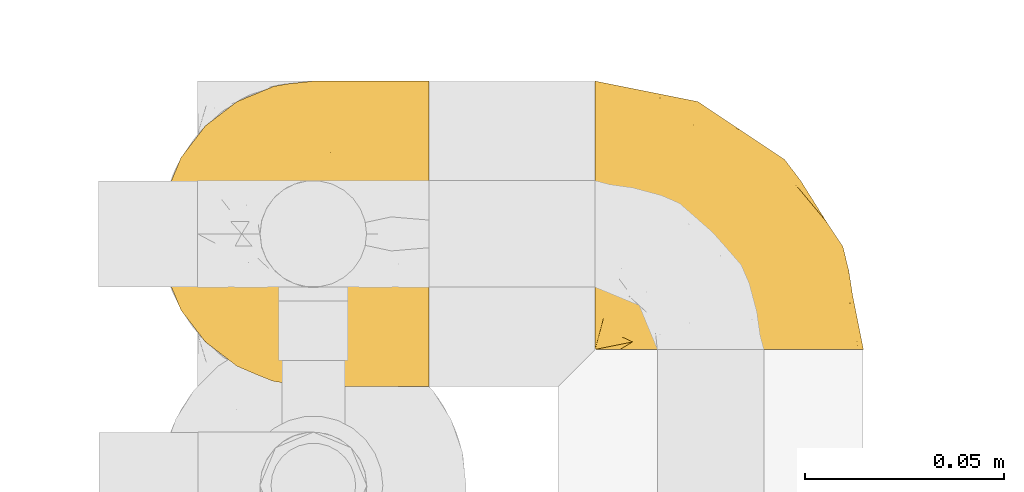
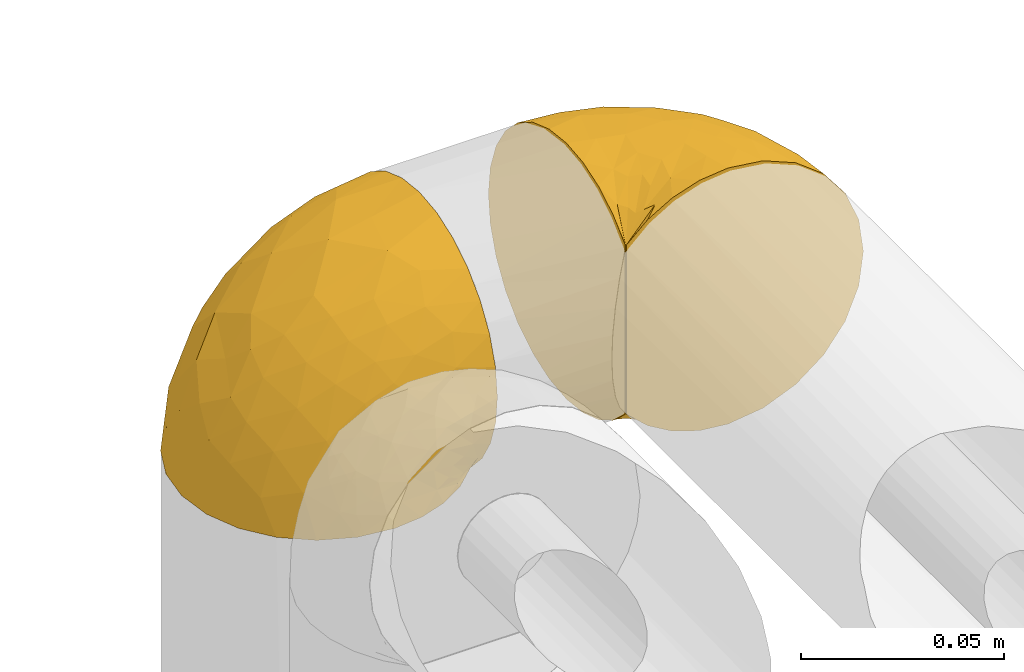
# One storey, part 85 of 827: 2 coverings.
"""IFC2X3 building model written with IfcOpenShell, lengths in millimetres."""

from ifc_helpers import new_model, entity, si_unit, converted_unit, derived_unit, direction, frame, origin, place, context, subcontext, project, spatial, faceted_brep, element, save


model = new_model("IFC2X3")

# Units and contexts
model_context = context("Model", 3, precision=0.01, world=origin(), true_north=direction((6.12303176911189e-17, 1.0)))
body_context = subcontext(model_context, "Body", "Model", "MODEL_VIEW")
ifc_project = project(units=[si_unit("LENGTHUNIT", "METRE", prefix="MILLI"), si_unit("AREAUNIT", "SQUARE_METRE"), si_unit("VOLUMEUNIT", "CUBIC_METRE"), converted_unit("PLANEANGLEUNIT", "DEGREE", entity("IfcRatioMeasure", 0.0174532925199433), si_unit("PLANEANGLEUNIT", "RADIAN"), dimensions=[0, 0, 0, 0, 0, 0, 0]), si_unit("MASSUNIT", "GRAM", prefix="KILO"), derived_unit("MASSDENSITYUNIT", [(si_unit("MASSUNIT", "GRAM", prefix="KILO"), 1), (si_unit("LENGTHUNIT", "METRE"), -3)]), derived_unit("MOMENTOFINERTIAUNIT", [(si_unit("LENGTHUNIT", "METRE"), 4)]), si_unit("TIMEUNIT", "SECOND"), si_unit("FREQUENCYUNIT", "HERTZ"), si_unit("THERMODYNAMICTEMPERATUREUNIT", "DEGREE_CELSIUS"), derived_unit("THERMALTRANSMITTANCEUNIT", [(si_unit("MASSUNIT", "GRAM", prefix="KILO"), 1), (si_unit("THERMODYNAMICTEMPERATUREUNIT", "KELVIN"), -1), (si_unit("TIMEUNIT", "SECOND"), -3)]), derived_unit("VOLUMETRICFLOWRATEUNIT", [(si_unit("LENGTHUNIT", "METRE"), 3), (si_unit("TIMEUNIT", "SECOND"), -1)]), derived_unit("MASSFLOWRATEUNIT", [(si_unit("MASSUNIT", "GRAM", prefix="KILO"), 1), (si_unit("TIMEUNIT", "SECOND"), -1)]), derived_unit("ROTATIONALFREQUENCYUNIT", [(si_unit("TIMEUNIT", "SECOND"), -1)]), si_unit("ELECTRICCURRENTUNIT", "AMPERE"), si_unit("ELECTRICVOLTAGEUNIT", "VOLT"), si_unit("POWERUNIT", "WATT"), si_unit("FORCEUNIT", "NEWTON", prefix="KILO"), si_unit("ILLUMINANCEUNIT", "LUX"), si_unit("LUMINOUSFLUXUNIT", "LUMEN"), si_unit("LUMINOUSINTENSITYUNIT", "CANDELA"), derived_unit("USERDEFINED", [(si_unit("MASSUNIT", "GRAM", prefix="KILO"), -1), (si_unit("LENGTHUNIT", "METRE"), -2), (si_unit("TIMEUNIT", "SECOND"), 3), (si_unit("LUMINOUSFLUXUNIT", "LUMEN"), 1)]), derived_unit("LINEARVELOCITYUNIT", [(si_unit("LENGTHUNIT", "METRE"), 1), (si_unit("TIMEUNIT", "SECOND"), -1)]), si_unit("PRESSUREUNIT", "PASCAL"), derived_unit("USERDEFINED", [(si_unit("LENGTHUNIT", "METRE"), -2), (si_unit("MASSUNIT", "GRAM", prefix="KILO"), 1), (si_unit("TIMEUNIT", "SECOND"), -2)]), derived_unit("LINEARFORCEUNIT", [(si_unit("MASSUNIT", "GRAM", prefix="KILO"), 1), (si_unit("LENGTHUNIT", "METRE"), 1), (si_unit("TIMEUNIT", "SECOND"), -2), (si_unit("LENGTHUNIT", "METRE"), -1)]), derived_unit("PLANARFORCEUNIT", [(si_unit("MASSUNIT", "GRAM", prefix="KILO"), 1), (si_unit("LENGTHUNIT", "METRE"), 1), (si_unit("TIMEUNIT", "SECOND"), -2), (si_unit("LENGTHUNIT", "METRE"), -2)])], contexts=[model_context])

# Site, building, storey
site_placement = place(None, origin())
site = spatial("IfcSite", under=ifc_project, at=site_placement, CompositionType="ELEMENT")
building_placement = place(site_placement, origin())
building = spatial("IfcBuilding", under=site, at=building_placement, CompositionType="ELEMENT")
storey_placement = place(building_placement, frame((0.0, 0.0, 28200.0)))
storey = spatial("IfcBuildingStorey", under=building, at=storey_placement, Name="08", CompositionType="ELEMENT", Elevation=28200.0)

# Coverings
covering_1_placement = place(storey_placement, frame((18846.09, 12179.47, 1869.3)))
element("IfcCovering", 1, at=covering_1_placement, inside=storey, Name=":ADSK_", ObjectType=":ADSK_", PredefinedType="INSULATION", context=body_context, shape_type="Brep", body=[
    faceted_brep([(69.15, 74.68, 47.38), (69.15, 70.1, 54.67), (69.15, 64.01, 60.76), (69.15, 56.72, 65.34), (69.15, 48.6, 68.18), (69.15, 40.05, 69.15), (69.15, 31.49, 68.18), (69.15, 23.36, 65.33), (69.15, 16.07, 60.75), (69.15, 9.98, 54.66), (69.15, 5.4, 47.37), (69.15, 2.56, 39.25), (69.15, 1.6, 30.7), (69.15, 2.46, 22.59), (69.15, 5.01, 14.86), (69.15, 9.13, 7.84), (69.15, 14.62, 1.85), (69.15, 16.82, 1.85), (69.15, 18.56, 1.85), (69.15, 20.52, 1.85), (69.15, 22.49, 1.85), (69.15, 24.46, 1.85), (69.15, 26.42, 1.85), (69.15, 28.39, 1.85), (69.15, 30.36, 1.85), (69.15, 32.55, 1.85), (69.15, 34.75, 1.85), (69.15, 36.94, 1.85), (69.15, 39.13, 1.85), (69.15, 41.33, 1.85), (69.15, 43.52, 1.85), (69.15, 45.72, 1.85), (69.15, 47.91, 1.85), (69.15, 50.11, 1.85), (69.15, 52.3, 1.85), (69.15, 54.49, 1.85), (69.15, 56.69, 1.85), (69.15, 58.88, 1.85), (69.15, 61.08, 1.85), (69.15, 63.27, 1.85), (69.15, 65.47, 1.85), (69.15, 70.97, 7.85), (69.15, 75.09, 14.88), (69.15, 77.64, 22.61), (69.15, 78.5, 30.7), (69.15, 77.53, 39.26), (68.89, 14.62, 1.6), (62.89, 9.12, 1.6), (55.87, 5.0, 1.6), (48.14, 2.46, 1.6), (40.05, 1.6, 1.6), (30.09, 2.91, 1.6), (20.82, 6.75, 1.6), (12.86, 12.86, 1.6), (6.75, 20.82, 1.6), (2.91, 30.09, 1.6), (1.6, 40.05, 1.6), (2.91, 50.0, 1.6), (6.75, 59.27, 1.6), (12.86, 67.23, 1.6), (20.82, 73.34, 1.6), (30.09, 77.19, 1.6), (40.05, 78.5, 1.6), (48.14, 77.63, 1.6), (55.87, 75.09, 1.6), (62.89, 70.97, 1.6), (68.89, 65.47, 1.6), (68.89, 63.27, 1.6), (68.89, 62.29, 1.6), (68.89, 60.7, 1.6), (68.89, 59.11, 1.6), (68.89, 57.52, 1.6), (68.89, 55.93, 1.6), (68.89, 54.34, 1.6), (68.89, 52.76, 1.6), (68.89, 51.17, 1.6), (68.89, 49.58, 1.6), (68.89, 47.99, 1.6), (68.89, 46.4, 1.6), (68.89, 44.81, 1.6), (68.89, 43.22, 1.6), (68.89, 41.63, 1.6), (68.89, 40.05, 1.6), (68.89, 38.46, 1.6), (68.89, 36.87, 1.6), (68.89, 35.28, 1.6), (68.89, 33.69, 1.6), (68.89, 32.1, 1.6), (68.89, 30.51, 1.6), (68.89, 28.92, 1.6), (68.89, 27.33, 1.6), (68.89, 25.37, 1.6), (68.89, 23.4, 1.6), (68.89, 21.21, 1.6), (68.89, 19.01, 1.6), (68.89, 16.82, 1.6), (68.97, 42.32, 1.78), (68.96, 44.02, 1.77), (68.97, 47.13, 1.78), (68.97, 48.74, 1.77), (68.98, 23.57, 1.79), (68.97, 25.13, 1.78), (68.96, 61.34, 1.76), (68.96, 22.02, 1.77), (68.96, 29.72, 1.77), (68.96, 56.73, 1.76), (68.96, 55.14, 1.77), (68.96, 37.66, 1.77), (69.0, 64.12, 1.8), (68.96, 28.13, 1.76), (68.96, 26.62, 1.77), (68.97, 31.46, 1.78), (68.96, 16.16, 1.77), (68.96, 39.16, 1.77), (68.96, 50.37, 1.76), (68.97, 17.69, 1.77), (68.97, 19.17, 1.78), (68.97, 62.78, 1.77), (68.96, 58.35, 1.77), (68.96, 45.53, 1.77), (68.97, 59.91, 1.78), (68.97, 65.47, 1.77), (69.02, 65.47, 1.8), (69.08, 65.47, 1.82), (68.97, 14.62, 1.77), (68.94, 14.62, 1.72), (68.92, 14.62, 1.66), (68.96, 20.59, 1.76), (68.96, 32.99, 1.77), (68.95, 34.48, 1.76), (68.96, 51.91, 1.77), (68.92, 65.47, 1.66), (68.94, 65.47, 1.72), (68.98, 53.48, 1.78), (69.08, 14.62, 1.82), (69.02, 14.62, 1.8), (68.96, 40.77, 1.77), (68.97, 35.97, 1.78), (61.33, 7.84, 3.72), (53.1, 3.53, 7.41), (63.33, 8.32, 6.13), (49.27, 1.6, 21.47), (55.53, 2.19, 19.34), (54.6, 1.6, 26.8), (41.99, 1.6, 8.87), (57.07, 4.57, 9.2), (57.95, 3.96, 12.79), (51.56, 2.28, 14.62), (41.58, 1.6, 7.34), (61.7, 7.69, 5.33), (63.33, 3.53, 17.64), (65.0, 8.32, 7.7), (67.02, 7.84, 9.41), (61.87, 1.6, 28.75), (43.94, 1.6, 16.15), (61.21, 4.34, 14.14), (63.4, 1.6, 29.16), (33.11, 29.63, 57.02), (52.82, 27.34, 64.92), (43.3, 40.05, 64.0), (33.73, 2.39, 11.92), (36.52, 2.43, 19.16), (24.87, 9.07, 28.65), (14.17, 16.64, 24.62), (18.43, 9.54, 15.19), (28.67, 4.52, 18.36), (26.0, 4.52, 9.2), (49.25, 7.49, 46.98), (59.72, 7.49, 50.24), (55.1, 12.85, 56.1), (44.72, 2.35, 28.97), (34.15, 22.66, 54.46), (5.25, 32.9, 21.34), (6.75, 25.33, 18.4), (55.54, 40.05, 66.44), (10.47, 16.64, 12.07), (25.49, 19.99, 45.49), (35.53, 16.37, 50.57), (48.22, 3.26, 36.04), (58.71, 3.75, 42.07), (57.42, 19.58, 62.12), (34.84, 7.5, 37.37), (36.87, 4.04, 29.39), (45.01, 13.94, 53.59), (44.4, 19.58, 58.06), (23.96, 28.21, 49.27), (11.2, 24.75, 29.63), (10.56, 31.42, 33.21), (16.81, 26.2, 40.1), (17.38, 33.36, 44.08), (21.38, 40.05, 49.36), (32.34, 40.05, 56.68), (4.3, 40.05, 15.2), (20.65, 16.14, 35.57), (29.66, 12.85, 41.7), (39.6, 10.47, 46.4), (42.55, 6.49, 41.41), (6.74, 40.05, 27.45), (14.06, 40.05, 38.4), (26.84, 75.57, 12.99), (5.28, 47.37, 21.33), (18.52, 52.91, 42.89), (33.13, 50.46, 57.04), (55.1, 67.23, 56.11), (57.43, 60.5, 62.13), (20.72, 70.55, 21.89), (11.46, 63.45, 16.62), (17.69, 62.61, 32.9), (49.26, 72.6, 46.99), (59.73, 72.6, 50.25), (58.71, 76.34, 42.08), (29.72, 59.34, 49.91), (35.35, 77.76, 15.6), (43.94, 78.5, 16.15), (41.99, 78.5, 8.87), (63.4, 78.5, 29.16), (4.93, 53.16, 13.16), (17.46, 70.55, 10.83), (10.94, 48.88, 33.8), (8.92, 54.76, 25.02), (52.83, 52.74, 64.92), (29.34, 71.93, 32.83), (30.26, 75.79, 20.56), (44.4, 60.5, 58.07), (39.06, 77.86, 21.46), (43.06, 77.64, 28.1), (54.6, 78.5, 26.8), (49.27, 78.5, 21.47), (42.69, 67.23, 51.29), (48.2, 76.82, 36.04), (61.87, 78.5, 28.75), (33.44, 77.8, 8.45), (29.67, 67.23, 41.73), (38.5, 73.2, 39.27), (23.35, 67.66, 33.56), (34.97, 75.99, 27.29), (53.1, 76.57, 7.41), (59.68, 73.21, 3.51), (62.19, 71.93, 4.68), (64.11, 71.07, 5.52), (57.97, 75.09, 8.75), (57.95, 76.13, 12.79), (63.33, 76.57, 17.65), (51.77, 77.69, 13.9), (67.02, 72.26, 9.42), (64.98, 71.77, 7.68), (55.53, 77.9, 19.33), (61.22, 75.75, 14.13)], [[[0, 1, 2, 3, 4, 5, 6, 7, 8, 9, 10, 11, 12, 13, 14, 15, 16, 17, 18, 19, 20, 21, 22, 23, 24, 25, 26, 27, 28, 29, 30, 31, 32, 33, 34, 35, 36, 37, 38, 39, 40, 41, 42, 43, 44, 45]], [[46, 47, 48, 49, 50, 51, 52, 53, 54, 55, 56, 57, 58, 59, 60, 61, 62, 63, 64, 65, 66, 67, 68, 69, 70, 71, 72, 73, 74, 75, 76, 77, 78, 79, 80, 81, 82, 83, 84, 85, 86, 87, 88, 89, 90, 91, 92, 93, 94, 95]], [[96, 97, 30]], [[98, 77, 99]], [[100, 101, 21]], [[69, 68, 102]], [[20, 19, 103]], [[24, 23, 104]], [[20, 103, 100]], [[72, 105, 106]], [[84, 83, 107]], [[89, 88, 104]], [[108, 67, 66]], [[109, 110, 90]], [[111, 25, 24]], [[112, 17, 16]], [[82, 113, 83]], [[109, 23, 22]], [[114, 76, 75]], [[105, 36, 106]], [[104, 111, 24]], [[18, 115, 116]], [[97, 96, 80]], [[67, 108, 117]], [[105, 71, 118]], [[31, 97, 119]], [[102, 120, 69]], [[108, 121, 122, 123, 40]], [[112, 95, 115]], [[17, 115, 18]], [[94, 116, 115]], [[117, 68, 67]], [[38, 117, 39]], [[112, 124, 125, 126, 46]], [[17, 112, 115]], [[70, 120, 118]], [[39, 117, 108]], [[120, 38, 37]], [[120, 37, 118]], [[120, 70, 69]], [[116, 94, 127]], [[128, 86, 129]], [[117, 38, 102]], [[74, 130, 75]], [[99, 33, 32]], [[115, 95, 94]], [[39, 108, 40]], [[108, 66, 131, 132, 121]], [[105, 72, 71]], [[118, 37, 36]], [[71, 70, 118]], [[35, 106, 36]], [[36, 105, 118]], [[35, 133, 106]], [[74, 73, 133]], [[106, 133, 73]], [[99, 114, 33]], [[133, 35, 34]], [[73, 72, 106]], [[95, 112, 46]], [[112, 16, 134, 135, 124]], [[130, 114, 75]], [[99, 76, 114]], [[114, 130, 33]], [[34, 33, 130]], [[78, 77, 98]], [[98, 119, 78]], [[130, 133, 34]], [[133, 130, 74]], [[79, 97, 80]], [[98, 99, 32]], [[98, 32, 31]], [[77, 76, 99]], [[97, 79, 119]], [[136, 96, 29]], [[30, 97, 31]], [[136, 29, 28]], [[81, 80, 96]], [[29, 96, 30]], [[31, 119, 98]], [[119, 79, 78]], [[96, 136, 81]], [[82, 81, 136]], [[113, 107, 83]], [[84, 107, 137]], [[107, 27, 137]], [[113, 28, 107]], [[27, 107, 28]], [[85, 84, 137]], [[137, 27, 26]], [[113, 136, 28]], [[136, 113, 82]], [[109, 89, 104]], [[86, 85, 129]], [[89, 109, 90]], [[111, 87, 128]], [[26, 129, 137]], [[88, 111, 104]], [[25, 111, 128]], [[22, 110, 109]], [[23, 109, 104]], [[110, 91, 90]], [[100, 92, 101]], [[110, 22, 101]], [[91, 110, 101]], [[116, 19, 18]], [[111, 88, 87]], [[127, 103, 19]], [[25, 128, 26]], [[86, 128, 87]], [[128, 129, 26]], [[137, 129, 85]], [[120, 102, 38]], [[117, 102, 68]], [[91, 101, 92]], [[21, 101, 22]], [[93, 92, 103]], [[100, 21, 20]], [[100, 103, 92]], [[127, 93, 103]], [[93, 127, 94]], [[116, 127, 19]], [[126, 138, 47]], [[48, 138, 139]], [[140, 125, 124]], [[141, 142, 143]], [[144, 49, 139]], [[145, 140, 146]], [[48, 139, 49]], [[139, 145, 147]], [[49, 144, 148, 50]], [[126, 125, 149]], [[14, 13, 150]], [[151, 146, 140]], [[149, 140, 145]], [[152, 151, 135]], [[152, 14, 150]], [[16, 15, 134]], [[13, 153, 150]], [[124, 151, 140]], [[141, 147, 142]], [[14, 152, 15]], [[15, 152, 134]], [[47, 46, 126]], [[139, 154, 144]], [[138, 48, 47]], [[125, 140, 149]], [[135, 134, 152]], [[146, 155, 142]], [[145, 146, 147]], [[149, 139, 138]], [[147, 141, 154]], [[147, 146, 142]], [[139, 147, 154]], [[139, 149, 145]], [[149, 138, 126]], [[155, 146, 151]], [[150, 143, 142]], [[152, 155, 151]], [[150, 142, 155]], [[13, 12, 156, 153]], [[153, 143, 150]], [[152, 150, 155]], [[151, 124, 135]], [[157, 158, 159]], [[160, 154, 161]], [[162, 163, 164]], [[165, 166, 160]], [[167, 168, 169]], [[141, 170, 161]], [[156, 12, 11]], [[158, 157, 171]], [[172, 55, 173]], [[158, 6, 174]], [[175, 54, 53]], [[52, 166, 164]], [[52, 164, 53]], [[54, 175, 173]], [[166, 52, 51]], [[176, 177, 171]], [[178, 143, 179]], [[156, 11, 179]], [[8, 7, 180]], [[169, 9, 8]], [[179, 143, 153, 156]], [[179, 11, 10]], [[168, 179, 10]], [[181, 162, 182]], [[179, 167, 178]], [[183, 184, 177]], [[183, 169, 184]], [[176, 171, 185]], [[172, 186, 187]], [[158, 7, 6]], [[159, 158, 174]], [[184, 180, 158]], [[54, 173, 55]], [[180, 169, 8]], [[188, 189, 187]], [[9, 168, 10]], [[186, 188, 187]], [[190, 157, 159, 191]], [[55, 172, 192]], [[176, 193, 194]], [[161, 170, 182]], [[162, 164, 165]], [[175, 164, 163]], [[51, 50, 148]], [[167, 195, 196]], [[178, 182, 170]], [[6, 5, 174]], [[158, 180, 7]], [[169, 180, 184]], [[169, 168, 9]], [[179, 168, 167]], [[182, 162, 165]], [[162, 194, 193]], [[161, 165, 160]], [[195, 181, 196]], [[192, 172, 197]], [[192, 56, 55]], [[189, 190, 198]], [[198, 197, 187]], [[172, 187, 197]], [[185, 189, 188]], [[198, 187, 189]], [[186, 172, 173]], [[173, 163, 186]], [[193, 186, 163]], [[176, 185, 188]], [[185, 157, 190]], [[188, 186, 193]], [[177, 176, 194]], [[188, 193, 176]], [[162, 193, 163]], [[195, 177, 194]], [[171, 177, 184]], [[181, 195, 194]], [[183, 167, 169]], [[162, 181, 194]], [[196, 182, 178]], [[158, 171, 184]], [[171, 157, 185]], [[177, 195, 183]], [[167, 183, 195]], [[182, 196, 181]], [[178, 170, 143]], [[178, 167, 196]], [[164, 175, 53]], [[173, 175, 163]], [[160, 51, 148]], [[164, 166, 165]], [[51, 160, 166]], [[160, 148, 144, 154]], [[141, 161, 154]], [[182, 165, 161]], [[190, 189, 185]], [[143, 170, 141]], [[60, 199, 61]], [[197, 200, 192]], [[201, 190, 202]], [[200, 57, 192]], [[203, 204, 2]], [[205, 206, 207]], [[208, 209, 210]], [[211, 207, 201]], [[212, 213, 214]], [[45, 215, 210]], [[216, 206, 58]], [[45, 44, 215]], [[59, 217, 60]], [[60, 217, 199]], [[0, 45, 210]], [[218, 201, 219]], [[202, 159, 220]], [[205, 221, 222]], [[223, 204, 203]], [[1, 203, 2]], [[57, 200, 216]], [[220, 3, 204]], [[220, 174, 4]], [[1, 0, 209]], [[212, 224, 213]], [[225, 226, 227]], [[228, 223, 203]], [[208, 210, 229]], [[210, 226, 229]], [[3, 220, 4]], [[58, 206, 59]], [[209, 203, 1]], [[202, 220, 223]], [[228, 203, 208]], [[202, 211, 201]], [[3, 2, 204]], [[202, 190, 191, 159]], [[210, 215, 230, 226]], [[199, 212, 231]], [[232, 233, 221]], [[233, 208, 229]], [[207, 206, 219]], [[217, 206, 205]], [[227, 224, 225]], [[233, 232, 228]], [[201, 207, 219]], [[234, 232, 221]], [[218, 219, 200]], [[202, 223, 211]], [[174, 220, 159]], [[174, 5, 4]], [[61, 231, 62]], [[220, 204, 223]], [[210, 209, 0]], [[203, 209, 208]], [[225, 233, 229]], [[224, 227, 213]], [[221, 233, 235]], [[57, 56, 192]], [[198, 218, 197]], [[200, 219, 216]], [[201, 198, 190]], [[197, 218, 200]], [[198, 201, 218]], [[206, 216, 219]], [[58, 57, 216]], [[231, 212, 214]], [[222, 212, 199]], [[228, 211, 223]], [[207, 211, 232]], [[62, 231, 214]], [[199, 231, 61]], [[233, 228, 208]], [[211, 228, 232]], [[222, 221, 235]], [[234, 205, 207]], [[206, 217, 59]], [[199, 217, 205]], [[205, 222, 199]], [[224, 222, 235]], [[222, 224, 212]], [[224, 235, 225]], [[233, 225, 235]], [[226, 225, 229]], [[205, 234, 221]], [[207, 232, 234]], [[63, 214, 236]], [[214, 213, 236]], [[214, 63, 62]], [[237, 236, 238]], [[238, 132, 131]], [[236, 237, 64]], [[239, 240, 241]], [[63, 236, 64]], [[131, 66, 65]], [[237, 131, 65]], [[242, 230, 43]], [[237, 65, 64]], [[239, 121, 132]], [[42, 242, 43]], [[241, 240, 243]], [[41, 123, 244]], [[43, 230, 215, 44]], [[244, 122, 245]], [[227, 246, 243]], [[241, 243, 246]], [[121, 239, 245]], [[41, 40, 123]], [[132, 238, 239]], [[244, 42, 41]], [[131, 237, 238]], [[240, 239, 238]], [[245, 239, 241]], [[247, 241, 246]], [[247, 244, 245]], [[238, 236, 240]], [[243, 236, 213]], [[236, 243, 240]], [[226, 246, 227]], [[243, 213, 227]], [[226, 242, 246]], [[241, 247, 245]], [[246, 242, 247]], [[244, 247, 242]], [[242, 226, 230]], [[42, 244, 242]], [[122, 244, 123]], [[122, 121, 245]]]),
])
covering_2_placement = place(storey_placement, frame((18955.44, 12188.82, 1859.95)))
element("IfcCovering", 2, at=covering_2_placement, inside=storey, Name=":ADSK_", ObjectType=":ADSK_", PredefinedType="INSULATION", context=body_context, shape_type="Brep", body=[
    faceted_brep([(1.6, 47.38, 74.68), (1.6, 54.67, 70.1), (1.6, 60.76, 64.01), (1.6, 65.34, 56.72), (1.6, 68.18, 48.6), (1.6, 69.15, 40.05), (1.6, 68.18, 31.49), (1.6, 65.33, 23.36), (1.6, 60.75, 16.07), (1.6, 54.66, 9.98), (1.6, 47.37, 5.4), (1.6, 39.25, 2.56), (1.6, 30.7, 1.6), (1.6, 22.59, 2.46), (1.6, 14.86, 5.01), (1.6, 7.84, 9.13), (1.6, 1.85, 14.62), (1.6, 1.85, 16.82), (1.6, 1.85, 18.56), (1.6, 1.85, 20.52), (1.6, 1.85, 22.49), (1.6, 1.85, 24.46), (1.6, 1.85, 26.42), (1.6, 1.85, 28.39), (1.6, 1.85, 30.36), (1.6, 1.85, 32.55), (1.6, 1.85, 34.75), (1.6, 1.85, 36.94), (1.6, 1.85, 39.13), (1.6, 1.85, 41.33), (1.6, 1.85, 43.52), (1.6, 1.85, 45.72), (1.6, 1.85, 47.91), (1.6, 1.85, 50.11), (1.6, 1.85, 52.3), (1.6, 1.85, 54.49), (1.6, 1.85, 56.69), (1.6, 1.85, 58.88), (1.6, 1.85, 61.08), (1.6, 1.85, 63.27), (1.6, 1.85, 65.47), (1.6, 7.85, 70.97), (1.6, 14.88, 75.09), (1.6, 22.61, 77.64), (1.6, 30.7, 78.5), (1.6, 39.26, 77.53), (1.85, 1.6, 14.62), (7.85, 1.6, 9.12), (14.87, 1.6, 5.0), (22.6, 1.6, 2.46), (30.7, 1.6, 1.6), (40.65, 1.6, 2.91), (49.92, 1.6, 6.75), (57.88, 1.6, 12.86), (63.99, 1.6, 20.82), (67.84, 1.6, 30.09), (69.15, 1.6, 40.05), (67.84, 1.6, 50.0), (63.99, 1.6, 59.27), (57.88, 1.6, 67.23), (49.92, 1.6, 73.34), (40.65, 1.6, 77.19), (30.7, 1.6, 78.5), (22.6, 1.6, 77.63), (14.87, 1.6, 75.09), (7.85, 1.6, 70.97), (1.85, 1.6, 65.47), (1.85, 1.6, 63.27), (1.85, 1.6, 62.29), (1.85, 1.6, 60.7), (1.85, 1.6, 59.11), (1.85, 1.6, 57.52), (1.85, 1.6, 55.93), (1.85, 1.6, 54.34), (1.85, 1.6, 52.76), (1.85, 1.6, 51.17), (1.85, 1.6, 49.58), (1.85, 1.6, 47.99), (1.85, 1.6, 46.4), (1.85, 1.6, 44.81), (1.85, 1.6, 43.22), (1.85, 1.6, 41.63), (1.85, 1.6, 40.05), (1.85, 1.6, 38.46), (1.85, 1.6, 36.87), (1.85, 1.6, 35.28), (1.85, 1.6, 33.69), (1.85, 1.6, 32.1), (1.85, 1.6, 30.51), (1.85, 1.6, 28.92), (1.85, 1.6, 27.33), (1.85, 1.6, 25.37), (1.85, 1.6, 23.4), (1.85, 1.6, 21.21), (1.85, 1.6, 19.01), (1.85, 1.6, 16.82), (1.77, 1.78, 42.32), (1.78, 1.77, 44.02), (1.77, 1.78, 47.13), (1.77, 1.77, 48.74), (1.76, 1.79, 23.57), (1.77, 1.78, 25.13), (1.79, 1.76, 61.34), (1.78, 1.77, 22.02), (1.78, 1.77, 29.72), (1.78, 1.76, 56.73), (1.78, 1.77, 55.14), (1.78, 1.77, 37.66), (1.74, 1.8, 64.12), (1.78, 1.76, 28.13), (1.78, 1.77, 26.62), (1.77, 1.78, 31.46), (1.78, 1.77, 16.16), (1.78, 1.77, 39.16), (1.78, 1.76, 50.37), (1.77, 1.77, 17.69), (1.77, 1.78, 19.17), (1.77, 1.77, 62.78), (1.78, 1.77, 58.35), (1.78, 1.77, 45.53), (1.77, 1.78, 59.91), (1.77, 1.77, 65.47), (1.72, 1.8, 65.47), (1.66, 1.82, 65.47), (1.77, 1.77, 14.62), (1.8, 1.72, 14.62), (1.82, 1.66, 14.62), (1.79, 1.76, 20.59), (1.78, 1.77, 32.99), (1.79, 1.76, 34.48), (1.78, 1.77, 51.91), (1.82, 1.66, 65.47), (1.8, 1.72, 65.47), (1.76, 1.78, 53.48), (1.66, 1.82, 14.62), (1.72, 1.8, 14.62), (1.78, 1.77, 40.77), (1.77, 1.78, 35.97), (9.41, 3.72, 7.84), (17.65, 7.41, 3.53), (7.41, 6.13, 8.32), (15.21, 19.34, 2.19), (7.41, 17.64, 3.53), (16.15, 26.8, 1.6), (28.75, 8.87, 1.6), (13.67, 9.2, 4.57), (12.79, 12.79, 3.96), (19.18, 14.62, 2.28), (29.16, 7.34, 1.6), (9.04, 5.33, 7.69), (5.74, 7.7, 8.32), (3.72, 9.41, 7.84), (8.87, 28.75, 1.6), (21.47, 21.47, 1.6), (26.8, 16.15, 1.6), (9.53, 14.14, 4.34), (7.34, 29.16, 1.6), (37.63, 57.02, 29.63), (17.92, 64.92, 27.34), (27.45, 64.0, 40.05), (37.01, 11.92, 2.39), (34.22, 19.16, 2.43), (45.87, 28.65, 9.07), (56.57, 24.62, 16.64), (52.31, 15.19, 9.54), (42.07, 18.36, 4.52), (44.74, 9.2, 4.52), (21.49, 46.98, 7.49), (11.02, 50.24, 7.49), (15.64, 56.1, 12.85), (26.02, 28.97, 2.35), (36.59, 54.46, 22.66), (65.49, 21.34, 32.9), (63.99, 18.4, 25.33), (15.2, 66.44, 40.05), (60.27, 12.07, 16.64), (45.25, 45.49, 19.99), (35.21, 50.57, 16.37), (22.52, 36.04, 3.26), (12.03, 42.07, 3.75), (13.32, 62.12, 19.58), (35.9, 37.37, 7.5), (33.87, 29.39, 4.04), (25.73, 53.59, 13.94), (26.34, 58.06, 19.58), (46.78, 49.27, 28.21), (59.54, 29.63, 24.75), (60.18, 33.21, 31.42), (53.93, 40.1, 26.2), (53.36, 44.08, 33.36), (49.36, 49.36, 40.05), (38.4, 56.68, 40.05), (66.44, 15.2, 40.05), (50.09, 35.57, 16.14), (41.08, 41.7, 12.85), (31.14, 46.4, 10.47), (28.19, 41.41, 6.49), (64.0, 27.45, 40.05), (56.68, 38.4, 40.05), (43.9, 12.99, 75.57), (65.46, 21.33, 47.37), (52.22, 42.89, 52.91), (37.61, 57.04, 50.46), (15.64, 56.11, 67.23), (13.31, 62.13, 60.5), (50.02, 21.89, 70.55), (59.28, 16.62, 63.45), (53.05, 32.9, 62.61), (21.48, 46.99, 72.6), (11.01, 50.25, 72.6), (12.03, 42.08, 76.34), (41.02, 49.91, 59.34), (35.39, 15.6, 77.76), (26.8, 16.15, 78.5), (28.75, 8.87, 78.5), (7.34, 29.16, 78.5), (65.81, 13.16, 53.16), (53.28, 10.83, 70.55), (59.8, 33.8, 48.88), (61.82, 25.02, 54.76), (17.91, 64.92, 52.74), (41.4, 32.83, 71.93), (40.48, 20.56, 75.79), (26.34, 58.07, 60.5), (31.68, 21.46, 77.86), (27.68, 28.1, 77.64), (16.15, 26.8, 78.5), (21.47, 21.47, 78.5), (28.05, 51.29, 67.23), (22.54, 36.04, 76.82), (8.87, 28.75, 78.5), (37.3, 8.45, 77.8), (41.07, 41.73, 67.23), (32.24, 39.27, 73.2), (47.4, 33.56, 67.66), (35.77, 27.29, 75.99), (17.65, 7.41, 76.57), (11.06, 3.51, 73.21), (8.55, 4.68, 71.93), (6.63, 5.52, 71.07), (12.77, 8.75, 75.09), (12.79, 12.79, 76.13), (7.41, 17.65, 76.57), (18.97, 13.9, 77.69), (3.72, 9.42, 72.26), (5.76, 7.68, 71.77), (15.21, 19.33, 77.9), (9.52, 14.13, 75.75)], [[[0, 1, 2, 3, 4, 5, 6, 7, 8, 9, 10, 11, 12, 13, 14, 15, 16, 17, 18, 19, 20, 21, 22, 23, 24, 25, 26, 27, 28, 29, 30, 31, 32, 33, 34, 35, 36, 37, 38, 39, 40, 41, 42, 43, 44, 45]], [[46, 47, 48, 49, 50, 51, 52, 53, 54, 55, 56, 57, 58, 59, 60, 61, 62, 63, 64, 65, 66, 67, 68, 69, 70, 71, 72, 73, 74, 75, 76, 77, 78, 79, 80, 81, 82, 83, 84, 85, 86, 87, 88, 89, 90, 91, 92, 93, 94, 95]], [[96, 97, 30]], [[98, 77, 99]], [[100, 101, 21]], [[69, 68, 102]], [[20, 19, 103]], [[24, 23, 104]], [[20, 103, 100]], [[72, 105, 106]], [[84, 83, 107]], [[89, 88, 104]], [[108, 67, 66]], [[109, 110, 90]], [[111, 25, 24]], [[112, 17, 16]], [[82, 113, 83]], [[109, 23, 22]], [[114, 76, 75]], [[105, 36, 106]], [[104, 111, 24]], [[18, 115, 116]], [[97, 96, 80]], [[67, 108, 117]], [[105, 71, 118]], [[31, 97, 119]], [[102, 120, 69]], [[108, 121, 122, 123, 40]], [[112, 95, 115]], [[17, 115, 18]], [[94, 116, 115]], [[117, 68, 67]], [[38, 117, 39]], [[112, 124, 125, 126, 46]], [[17, 112, 115]], [[70, 120, 118]], [[39, 117, 108]], [[120, 38, 37]], [[120, 37, 118]], [[120, 70, 69]], [[116, 94, 127]], [[128, 86, 129]], [[117, 38, 102]], [[74, 130, 75]], [[99, 33, 32]], [[115, 95, 94]], [[39, 108, 40]], [[108, 66, 131, 132, 121]], [[105, 72, 71]], [[118, 37, 36]], [[71, 70, 118]], [[35, 106, 36]], [[36, 105, 118]], [[35, 133, 106]], [[74, 73, 133]], [[106, 133, 73]], [[99, 114, 33]], [[133, 35, 34]], [[73, 72, 106]], [[95, 112, 46]], [[112, 16, 134, 135, 124]], [[130, 114, 75]], [[99, 76, 114]], [[114, 130, 33]], [[34, 33, 130]], [[78, 77, 98]], [[98, 119, 78]], [[130, 133, 34]], [[133, 130, 74]], [[79, 97, 80]], [[98, 99, 32]], [[98, 32, 31]], [[77, 76, 99]], [[97, 79, 119]], [[136, 96, 29]], [[30, 97, 31]], [[136, 29, 28]], [[81, 80, 96]], [[29, 96, 30]], [[31, 119, 98]], [[119, 79, 78]], [[96, 136, 81]], [[82, 81, 136]], [[113, 107, 83]], [[84, 107, 137]], [[107, 27, 137]], [[113, 28, 107]], [[27, 107, 28]], [[85, 84, 137]], [[137, 27, 26]], [[113, 136, 28]], [[136, 113, 82]], [[109, 89, 104]], [[86, 85, 129]], [[89, 109, 90]], [[111, 87, 128]], [[26, 129, 137]], [[88, 111, 104]], [[25, 111, 128]], [[22, 110, 109]], [[23, 109, 104]], [[110, 91, 90]], [[100, 92, 101]], [[110, 22, 101]], [[91, 110, 101]], [[116, 19, 18]], [[111, 88, 87]], [[127, 103, 19]], [[25, 128, 26]], [[86, 128, 87]], [[128, 129, 26]], [[137, 129, 85]], [[120, 102, 38]], [[117, 102, 68]], [[91, 101, 92]], [[21, 101, 22]], [[93, 92, 103]], [[100, 21, 20]], [[100, 103, 92]], [[127, 93, 103]], [[93, 127, 94]], [[116, 127, 19]], [[126, 138, 47]], [[48, 138, 139]], [[140, 125, 124]], [[141, 142, 143]], [[144, 49, 139]], [[145, 140, 146]], [[48, 139, 49]], [[139, 145, 147]], [[49, 144, 148, 50]], [[126, 125, 149]], [[14, 13, 142]], [[150, 146, 140]], [[149, 140, 145]], [[151, 150, 135]], [[151, 14, 142]], [[16, 15, 134]], [[13, 152, 142]], [[124, 150, 140]], [[141, 143, 153]], [[14, 151, 15]], [[15, 151, 134]], [[47, 46, 126]], [[139, 154, 144]], [[138, 48, 47]], [[125, 140, 149]], [[135, 134, 151]], [[146, 155, 141]], [[145, 146, 147]], [[149, 139, 138]], [[147, 153, 154]], [[147, 146, 141]], [[139, 147, 154]], [[139, 149, 145]], [[149, 138, 126]], [[147, 141, 153]], [[146, 150, 155]], [[151, 155, 150]], [[142, 141, 155]], [[13, 12, 156, 152]], [[152, 143, 142]], [[151, 142, 155]], [[150, 124, 135]], [[157, 158, 159]], [[160, 154, 161]], [[162, 163, 164]], [[165, 166, 160]], [[167, 168, 169]], [[153, 170, 161]], [[156, 12, 11]], [[158, 157, 171]], [[172, 55, 173]], [[158, 6, 174]], [[175, 54, 53]], [[52, 166, 164]], [[52, 164, 53]], [[54, 175, 173]], [[166, 52, 51]], [[176, 177, 171]], [[178, 143, 179]], [[156, 11, 179]], [[8, 7, 180]], [[169, 9, 8]], [[179, 143, 152, 156]], [[179, 11, 10]], [[168, 179, 10]], [[181, 162, 182]], [[179, 167, 178]], [[183, 184, 177]], [[183, 169, 184]], [[176, 171, 185]], [[172, 186, 187]], [[158, 7, 6]], [[159, 158, 174]], [[184, 180, 158]], [[54, 173, 55]], [[180, 169, 8]], [[188, 189, 187]], [[9, 168, 10]], [[186, 188, 187]], [[190, 157, 159, 191]], [[55, 172, 192]], [[176, 193, 194]], [[161, 170, 182]], [[162, 164, 165]], [[175, 164, 163]], [[51, 50, 148]], [[167, 195, 196]], [[178, 182, 170]], [[6, 5, 174]], [[158, 180, 7]], [[169, 180, 184]], [[169, 168, 9]], [[179, 168, 167]], [[182, 162, 165]], [[162, 194, 193]], [[161, 165, 160]], [[195, 181, 196]], [[192, 172, 197]], [[192, 56, 55]], [[189, 190, 198]], [[198, 197, 187]], [[172, 187, 197]], [[185, 189, 188]], [[198, 187, 189]], [[186, 172, 173]], [[173, 163, 186]], [[193, 186, 163]], [[176, 185, 188]], [[185, 157, 190]], [[188, 186, 193]], [[177, 176, 194]], [[188, 193, 176]], [[162, 193, 163]], [[195, 177, 194]], [[171, 177, 184]], [[181, 195, 194]], [[183, 167, 169]], [[162, 181, 194]], [[196, 182, 178]], [[158, 171, 184]], [[171, 157, 185]], [[177, 195, 183]], [[167, 183, 195]], [[182, 196, 181]], [[178, 170, 143]], [[178, 167, 196]], [[164, 175, 53]], [[173, 175, 163]], [[160, 51, 148]], [[164, 166, 165]], [[51, 160, 166]], [[160, 148, 144, 154]], [[153, 161, 154]], [[182, 165, 161]], [[190, 189, 185]], [[143, 170, 153]], [[60, 199, 61]], [[197, 200, 192]], [[201, 190, 202]], [[200, 57, 192]], [[203, 204, 2]], [[205, 206, 207]], [[208, 209, 210]], [[211, 207, 201]], [[212, 213, 214]], [[45, 215, 210]], [[216, 206, 58]], [[45, 44, 215]], [[59, 217, 60]], [[60, 217, 199]], [[0, 45, 210]], [[218, 201, 219]], [[202, 159, 220]], [[205, 221, 222]], [[223, 204, 203]], [[1, 203, 2]], [[57, 200, 216]], [[220, 3, 204]], [[220, 174, 4]], [[1, 0, 209]], [[212, 224, 213]], [[225, 226, 227]], [[228, 223, 203]], [[208, 210, 229]], [[210, 226, 229]], [[3, 220, 4]], [[58, 206, 59]], [[209, 203, 1]], [[202, 220, 223]], [[228, 203, 208]], [[202, 211, 201]], [[3, 2, 204]], [[202, 190, 191, 159]], [[210, 215, 230, 226]], [[199, 212, 231]], [[232, 233, 221]], [[233, 208, 229]], [[207, 206, 219]], [[217, 206, 205]], [[227, 224, 225]], [[233, 232, 228]], [[201, 207, 219]], [[234, 232, 221]], [[218, 219, 200]], [[202, 223, 211]], [[174, 220, 159]], [[174, 5, 4]], [[61, 231, 62]], [[220, 204, 223]], [[210, 209, 0]], [[203, 209, 208]], [[225, 233, 229]], [[224, 227, 213]], [[221, 233, 235]], [[57, 56, 192]], [[198, 218, 197]], [[200, 219, 216]], [[201, 198, 190]], [[197, 218, 200]], [[198, 201, 218]], [[206, 216, 219]], [[58, 57, 216]], [[231, 212, 214]], [[222, 212, 199]], [[228, 211, 223]], [[207, 211, 232]], [[62, 231, 214]], [[199, 231, 61]], [[233, 228, 208]], [[211, 228, 232]], [[222, 221, 235]], [[234, 205, 207]], [[206, 217, 59]], [[199, 217, 205]], [[205, 222, 199]], [[224, 222, 235]], [[222, 224, 212]], [[224, 235, 225]], [[233, 225, 235]], [[226, 225, 229]], [[205, 234, 221]], [[207, 232, 234]], [[63, 214, 236]], [[214, 213, 236]], [[214, 63, 62]], [[237, 236, 238]], [[238, 132, 131]], [[236, 237, 64]], [[239, 240, 241]], [[63, 236, 64]], [[131, 66, 65]], [[237, 131, 65]], [[242, 230, 43]], [[237, 65, 64]], [[239, 121, 132]], [[42, 242, 43]], [[241, 240, 243]], [[41, 123, 244]], [[43, 230, 215, 44]], [[244, 122, 245]], [[227, 246, 243]], [[241, 243, 246]], [[121, 239, 245]], [[41, 40, 123]], [[132, 238, 239]], [[244, 42, 41]], [[131, 237, 238]], [[240, 239, 238]], [[245, 239, 241]], [[247, 241, 246]], [[247, 244, 245]], [[238, 236, 240]], [[243, 236, 213]], [[236, 243, 240]], [[226, 246, 227]], [[243, 213, 227]], [[226, 242, 246]], [[241, 247, 245]], [[246, 242, 247]], [[244, 247, 242]], [[242, 226, 230]], [[42, 244, 242]], [[122, 244, 123]], [[122, 121, 245]]]),
])

save(model, "model.ifc")
